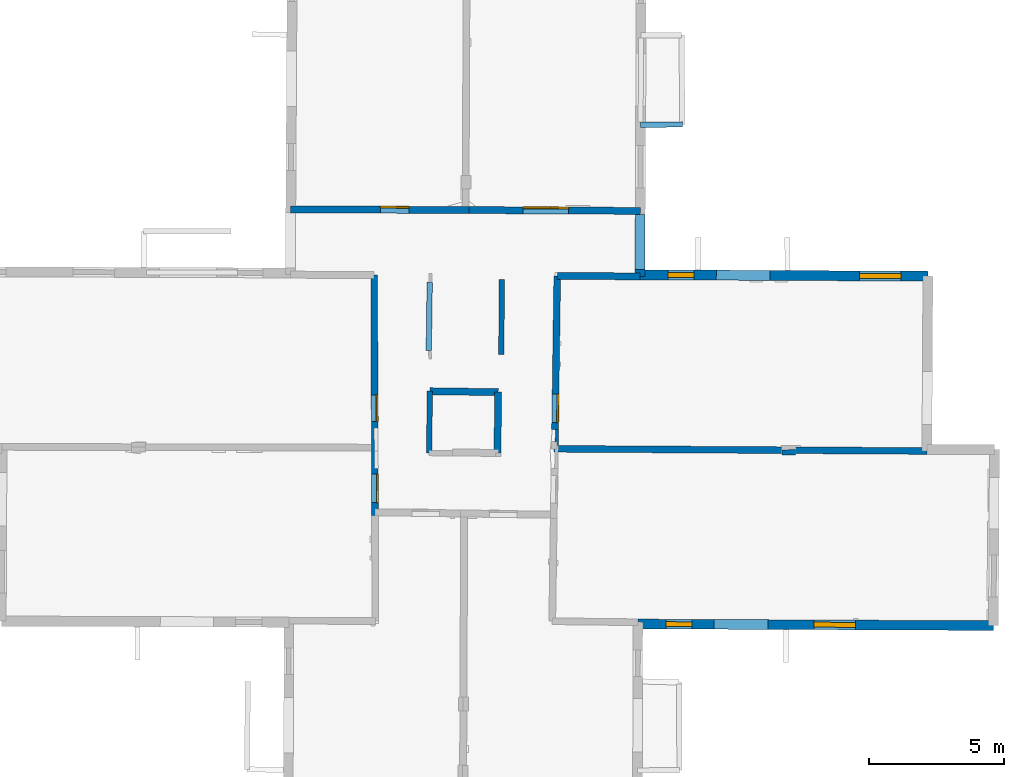
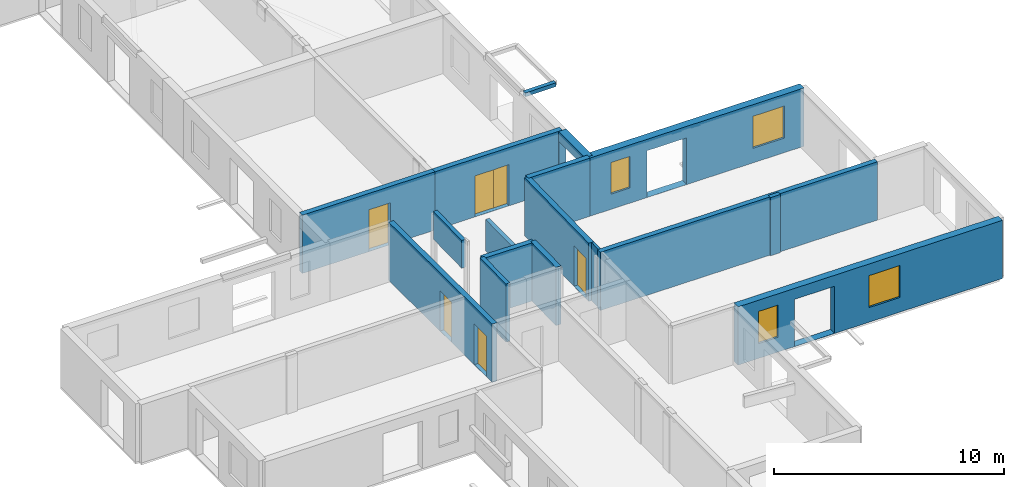
# One storey, part 5 of 15: 17 walls, 6 doors, 4 windows, 13 openings.
"""IFC2X3 building model written with IfcOpenShell, lengths in metres."""

from ifc_helpers import new_model, entity, si_unit, converted_unit, derived_unit, direction, frame, frame_2d, origin, origin_2d_with_axis, place, context, subcontext, project, spatial, polyline, rectangle, outline, extrude, source, transform, mapped, material, layer, layer_set, layer_usage, type_object, type_shapes, element, fill, save


model = new_model("IFC2X3")

# Units and contexts
model_context = context("Model", 3, precision=1e-05, world=origin(), true_north=direction((0.0, 1.0)))
body_context = subcontext(model_context, "Body", "Model", "MODEL_VIEW")
ifc_project = project(units=[si_unit("LENGTHUNIT", "METRE"), si_unit("AREAUNIT", "SQUARE_METRE"), si_unit("VOLUMEUNIT", "CUBIC_METRE"), converted_unit("PLANEANGLEUNIT", "DEGREE", entity("IfcRatioMeasure", 0.0174532925199433), si_unit("PLANEANGLEUNIT", "RADIAN"), dimensions=[0, 0, 0, 0, 0, 0, 0]), si_unit("MASSUNIT", "GRAM", prefix="KILO"), derived_unit("MASSDENSITYUNIT", [(si_unit("MASSUNIT", "GRAM", prefix="KILO"), 1), (si_unit("LENGTHUNIT", "METRE"), -3)]), derived_unit("MOMENTOFINERTIAUNIT", [(si_unit("LENGTHUNIT", "METRE"), 4)]), si_unit("TIMEUNIT", "SECOND"), si_unit("FREQUENCYUNIT", "HERTZ"), si_unit("THERMODYNAMICTEMPERATUREUNIT", "DEGREE_CELSIUS"), derived_unit("THERMALTRANSMITTANCEUNIT", [(si_unit("MASSUNIT", "GRAM", prefix="KILO"), 1), (si_unit("THERMODYNAMICTEMPERATUREUNIT", "KELVIN"), -1), (si_unit("TIMEUNIT", "SECOND"), -3)]), derived_unit("VOLUMETRICFLOWRATEUNIT", [(si_unit("LENGTHUNIT", "METRE"), 3), (si_unit("TIMEUNIT", "SECOND"), -1)]), si_unit("ELECTRICCURRENTUNIT", "AMPERE"), si_unit("ELECTRICVOLTAGEUNIT", "VOLT"), si_unit("POWERUNIT", "WATT"), si_unit("FORCEUNIT", "NEWTON", prefix="KILO"), si_unit("ILLUMINANCEUNIT", "LUX"), si_unit("LUMINOUSFLUXUNIT", "LUMEN"), si_unit("LUMINOUSINTENSITYUNIT", "CANDELA"), derived_unit("USERDEFINED", [(si_unit("MASSUNIT", "GRAM", prefix="KILO"), -1), (si_unit("LENGTHUNIT", "METRE"), -2), (si_unit("TIMEUNIT", "SECOND"), 3), (si_unit("LUMINOUSFLUXUNIT", "LUMEN"), 1)]), derived_unit("LINEARVELOCITYUNIT", [(si_unit("LENGTHUNIT", "METRE"), 1), (si_unit("TIMEUNIT", "SECOND"), -1)]), si_unit("PRESSUREUNIT", "PASCAL"), derived_unit("USERDEFINED", [(si_unit("LENGTHUNIT", "METRE"), -2), (si_unit("MASSUNIT", "GRAM", prefix="KILO"), 1), (si_unit("TIMEUNIT", "SECOND"), -2)]), derived_unit("LINEARFORCEUNIT", [(si_unit("MASSUNIT", "GRAM", prefix="KILO"), 1), (si_unit("LENGTHUNIT", "METRE"), 1), (si_unit("TIMEUNIT", "SECOND"), -2), (si_unit("LENGTHUNIT", "METRE"), -1)]), derived_unit("PLANARFORCEUNIT", [(si_unit("MASSUNIT", "GRAM", prefix="KILO"), 1), (si_unit("LENGTHUNIT", "METRE"), 1), (si_unit("TIMEUNIT", "SECOND"), -2), (si_unit("LENGTHUNIT", "METRE"), -2)])], contexts=[model_context])

# Site, building, storey
placement_1 = place(None, origin())
site = spatial("IfcSite", under=ifc_project, at=placement_1, CompositionType="ELEMENT")
building = spatial("IfcBuilding", under=site, at=placement_1, CompositionType="ELEMENT")
storey_placement = place(placement_1, frame((0.0, 0.0, 2.3807327747345)))
storey = spatial("IfcBuildingStorey", under=building, at=storey_placement, Name="Level 2", CompositionType="ELEMENT", Elevation=2.3807327747345)

# Wall
ifc_material_1 = material(Name="Default wall")
ifc_layer_1 = layer(ifc_material_1, 0.25)
ifc_layer_set_1 = layer_set([ifc_layer_1], Name="wall_thickness_0.2500")
ifc_layer_usage_1 = layer_usage(ifc_layer_set_1, "AXIS2", "POSITIVE", -0.125)
wall_type_1 = type_object("IfcWallType", Name="wall_thickness_0.2500", PredefinedType="STANDARD", material=ifc_layer_set_1)
wall_1_placement = place(storey_placement, frame((9.52517846311906, 19.4277841959483, 0.0), z_axis=(0.0, 0.0, 1.0), x_axis=(0.99998290217259, -0.00584768009418763, 0.0)))
element("IfcWallStandardCase", 1, at=wall_1_placement, inside=storey, type_object=wall_type_1, material=ifc_layer_usage_1, Name="Wall:724", ObjectType="Wall", context=body_context, shape_type="SweptSolid", body=[
    extrude(outline(polyline([(13.8512137696322, -0.125), (13.8512137696322, 0.125), (0.0, 0.125), (0.0, -0.125), (13.8512137696322, -0.125)])), origin(), (0.0, 0.0, 1.0), 3.08589615821838),
])

# Wall, opening, door
wall_2_placement = place(storey_placement, frame((9.63678529989591, 25.850561855109, 0.0), z_axis=(0.0, 0.0, 1.0), x_axis=(-0.0145015561496306, -0.999894846906033, 0.0)))
wall_2 = element("IfcWallStandardCase", 2, at=wall_2_placement, inside=storey, type_object=wall_type_1, material=ifc_layer_usage_1, Name="Wall:739", ObjectType="Wall", context=body_context, shape_type="SweptSolid", body=[
    extrude(outline(polyline([(5.69907225176459, -0.125), (5.69907225176459, 0.125), (0.0, 0.125), (0.0, -0.125), (5.69907225176459, -0.125)])), origin(), (0.0, 0.0, 1.0), 3.08589615821838),
])
opening_1_placement = place(wall_2_placement, frame((4.38407267580055, -0.125, 0.00526785850524902)))
opening_1 = element("IfcOpeningElement", 3, at=opening_1_placement, cuts=wall_2, Name="Opening : 1065 x 2145 : 474", ObjectType="Opening", context=body_context, shape_type="SweptSolid", body=[
    extrude(rectangle(XDim=1.065, YDim=2.145, at=frame_2d((1.0725, 0.5325), x_axis=(0.0, 1.0))), frame((0.0, 0.0, 0.0), z_axis=(0.0, 1.0, 0.0), x_axis=(0.0, 0.0, 1.0)), (0.0, 0.0, 1.0), 0.25),
])
ifc_material_2 = material(Name="Door Panel")
door_style_1 = type_object("IfcDoorStyle", Name="Door : 1065 x 2145mm", ConstructionType="NOTDEFINED", OperationType="SINGLE_SWING_RIGHT", ParameterTakesPrecedence=False, Sizeable=False, material=ifc_material_2)
shared_shape_1 = source(origin(), body_context, "Body", "SweptSolid", [
    extrude(rectangle(XDim=0.0625, YDim=1.065, at=origin_2d_with_axis()), frame((0.5325, 0.21875, 0.0), z_axis=(0.0, 0.0, 1.0), x_axis=(0.0, 1.0, 0.0)), (0.0, 0.0, 1.0), 2.145),
])
type_shapes(door_style_1, [shared_shape_1])
door_1_placement = place(opening_1_placement, origin())
door_1 = element("IfcDoor", 4, at=door_1_placement, inside=storey, type_object=door_style_1, Name="Door : 1065 x 2145mm : 90", ObjectType="Door : 1065 x 2145mm", OverallHeight=2.145, OverallWidth=1.065, context=body_context, shape_type="MappedRepresentation", body=[
    mapped(shared_shape_1, transform((0.0, 0.0, 0.0), scale=1.0)),
])
fill(opening_1, door_1)

# Wall, openings, doors
wall_3_placement = place(storey_placement, frame((2.8325803450543, 25.8867340874099, 0.0), z_axis=(0.0, 0.0, 1.0), x_axis=(0.00334229316421513, -0.999994414522604, 0.0)))
wall_3 = element("IfcWallStandardCase", 5, at=wall_3_placement, inside=storey, type_object=wall_type_1, material=ifc_layer_usage_1, Name="Wall:750", ObjectType="Wall", context=body_context, shape_type="SweptSolid", body=[
    extrude(outline(polyline([(8.94604720610364, -0.125), (8.94604720610364, 0.125), (0.0, 0.125), (0.0, -0.125), (8.94604720610364, -0.125)])), origin(), (0.0, 0.0, 1.0), 3.08589615821838),
])
opening_2_placement = place(wall_3_placement, frame((4.45362671444788, -0.125, 0.00526785850524902)))
opening_2 = element("IfcOpeningElement", 6, at=opening_2_placement, cuts=wall_3, Name="Opening : 985 x 2130 : 481", ObjectType="Opening", context=body_context, shape_type="SweptSolid", body=[
    extrude(rectangle(XDim=0.985, YDim=2.13, at=frame_2d((1.065, 0.4925), x_axis=(0.0, 1.0))), frame((0.0, 0.0, 0.0), z_axis=(0.0, 1.0, 0.0), x_axis=(0.0, 0.0, 1.0)), (0.0, 0.0, 1.0), 0.25),
])
opening_3_placement = place(wall_3_placement, frame((7.39870770809691, -0.125, 0.00526785850524902)))
opening_3 = element("IfcOpeningElement", 7, at=opening_3_placement, cuts=wall_3, Name="Opening : 1060 x 2155 : 482", ObjectType="Opening", context=body_context, shape_type="SweptSolid", body=[
    extrude(rectangle(XDim=1.06, YDim=2.155, at=frame_2d((1.0775, 0.53), x_axis=(0.0, 1.0))), frame((0.0, 0.0, 0.0), z_axis=(0.0, 1.0, 0.0), x_axis=(0.0, 0.0, 1.0)), (0.0, 0.0, 1.0), 0.25),
])
door_style_2 = type_object("IfcDoorStyle", Name="Door : 985 x 2130mm", ConstructionType="NOTDEFINED", OperationType="SINGLE_SWING_RIGHT", ParameterTakesPrecedence=False, Sizeable=False, material=ifc_material_2)
shared_shape_2 = source(origin(), body_context, "Body", "SweptSolid", [
    extrude(rectangle(XDim=0.0625, YDim=0.985, at=origin_2d_with_axis()), frame((0.4925, 0.21875, 0.0), z_axis=(0.0, 0.0, 1.0), x_axis=(0.0, 1.0, 0.0)), (0.0, 0.0, 1.0), 2.13),
])
type_shapes(door_style_2, [shared_shape_2])
door_2_placement = place(opening_2_placement, origin())
door_2 = element("IfcDoor", 8, at=door_2_placement, inside=storey, type_object=door_style_2, Name="Door : 985 x 2130mm : 92", ObjectType="Door : 985 x 2130mm", OverallHeight=2.13, OverallWidth=0.985, context=body_context, shape_type="MappedRepresentation", body=[
    mapped(shared_shape_2, transform((0.0, 0.0, 0.0), scale=1.0)),
])
fill(opening_2, door_2)
door_style_3 = type_object("IfcDoorStyle", Name="Door : 1060 x 2155mm", ConstructionType="NOTDEFINED", OperationType="SINGLE_SWING_RIGHT", ParameterTakesPrecedence=False, Sizeable=False, material=ifc_material_2)
shared_shape_3 = source(origin(), body_context, "Body", "SweptSolid", [
    extrude(rectangle(XDim=0.0625, YDim=1.06, at=origin_2d_with_axis()), frame((0.53, 0.21875, 0.0), z_axis=(0.0, 0.0, 1.0), x_axis=(0.0, 1.0, 0.0)), (0.0, 0.0, 1.0), 2.155),
])
type_shapes(door_style_3, [shared_shape_3])
door_3_placement = place(opening_3_placement, origin())
door_3 = element("IfcDoor", 9, at=door_3_placement, inside=storey, type_object=door_style_3, Name="Door : 1060 x 2155mm : 93", ObjectType="Door : 1060 x 2155mm", OverallHeight=2.155, OverallWidth=1.06, context=body_context, shape_type="MappedRepresentation", body=[
    mapped(shared_shape_3, transform((0.0, 0.0, 0.0), scale=1.0)),
])
fill(opening_3, door_3)

# Walls
ifc_layer_2 = layer(ifc_material_1, 0.2)
ifc_layer_set_2 = layer_set([ifc_layer_2], Name="wall_thickness_0.2000")
ifc_layer_usage_2 = layer_usage(ifc_layer_set_2, "AXIS2", "POSITIVE", -0.1)
wall_type_2 = type_object("IfcWallType", Name="wall_thickness_0.2000", PredefinedType="STANDARD", material=ifc_layer_set_2)
placement_2 = place(placement_1, frame((0.0, 0.0, 3.99499988555908)))
wall_4_placement = place(placement_2, frame((4.86172145837155, 23.0868806920624, 0.0), z_axis=(0.0, 0.0, 1.0), x_axis=(0.0138378963437509, 0.999904251728524, 0.0)))
element("IfcWallStandardCase", 10, at=wall_4_placement, inside=storey, type_object=wall_type_2, material=ifc_layer_usage_2, Name="Wall:716", ObjectType="Wall", context=body_context, shape_type="SweptSolid", body=[
    extrude(outline(polyline([(2.52999878903139, -0.1), (2.52999878903139, 0.1), (0.0, 0.1), (0.0, -0.1), (2.52999878903139, -0.1)])), origin(), (0.0, 0.0, 1.0), 1.4716290473938),
])
wall_5_placement = place(storey_placement, frame((7.57779153173863, 25.7257712059022, 0.0), z_axis=(0.0, 0.0, 1.0), x_axis=(-0.00726444214638793, -0.99997361359203, 0.0)))
element("IfcWallStandardCase", 11, at=wall_5_placement, inside=storey, type_object=wall_type_2, material=ifc_layer_usage_2, Name="Wall:773", ObjectType="Wall", context=body_context, shape_type="SweptSolid", body=[
    extrude(outline(polyline([(2.8000006397717, -0.1), (2.8000006397717, 0.1), (0.0, 0.1), (0.0, -0.1), (2.8000006397717, -0.1)])), origin(), (0.0, 0.0, 1.0), 1.65126729011536),
])
wall_6_placement = place(storey_placement, frame((17.9921527331697, 19.2920920371607, 0.0), z_axis=(0.0, 0.0, 1.0), x_axis=(0.999991416526295, 0.00414329261992554, 0.0)))
element("IfcWallStandardCase", 12, at=wall_6_placement, inside=storey, type_object=wall_type_2, material=ifc_layer_usage_2, Name="Wall:807", ObjectType="Wall", context=body_context, shape_type="SweptSolid", body=[
    extrude(outline(polyline([(0.504999680720817, -0.1), (0.504999680720817, 0.1), (0.0, 0.1), (0.0, -0.1), (0.504999680720817, -0.1)])), origin(), (0.0, 0.0, 1.0), 3.08589615821838),
])
placement_3 = place(placement_1, frame((0.0, 0.0, 5.26399993896484)))
wall_7_placement = place(placement_3, frame((12.7357337186194, 31.4702623237995, 0.0), z_axis=(0.0, 0.0, 1.0), x_axis=(0.999967695594601, 0.00803789569625922, 0.0)))
element("IfcWallStandardCase", 13, at=wall_7_placement, inside=storey, type_object=wall_type_2, material=ifc_layer_usage_2, Name="Wall:811", ObjectType="Wall", context=body_context, shape_type="SweptSolid", body=[
    extrude(outline(polyline([(1.54810947425704, -0.1), (1.54810947425704, 0.1), (0.0, 0.1), (0.0, -0.1), (1.54810947425704, -0.1)])), origin(), (0.0, 0.0, 1.0), 0.202628993988037),
])
wall_8_placement = place(storey_placement, frame((4.90475104188143, 21.5686303125142, 0.0), z_axis=(0.0, 0.0, 1.0), x_axis=(-0.0143994759418368, -0.999896322171754, 0.0)))
element("IfcWallStandardCase", 14, at=wall_8_placement, inside=storey, type_object=wall_type_2, material=ifc_layer_usage_2, Name="Wall:834", ObjectType="Wall", context=body_context, shape_type="SweptSolid", body=[
    extrude(outline(polyline([(2.2977102217278, -0.1), (2.2977102217278, 0.1), (0.0, 0.1), (0.0, -0.1), (2.2977102217278, -0.1)])), origin(), (0.0, 0.0, 1.0), 3.08589615821838),
])
ifc_layer_3 = layer(ifc_material_1, 0.259999990463257)
ifc_layer_set_3 = layer_set([ifc_layer_3], Name="wall_thickness_0.2600")
ifc_layer_usage_3 = layer_usage(ifc_layer_set_3, "AXIS2", "POSITIVE", -0.129999995231628)
wall_type_3 = type_object("IfcWallType", Name="wall_thickness_0.2600", PredefinedType="STANDARD", material=ifc_layer_set_3)
wall_9_placement = place(storey_placement, frame((9.6367857093137, 25.8505635935053, 0.0), z_axis=(0.0, 0.0, 1.0), x_axis=(0.999989396078705, -0.00460518513710446, 0.0)))
element("IfcWallStandardCase", 15, at=wall_9_placement, inside=storey, type_object=wall_type_3, material=ifc_layer_usage_3, Name="Wall:694", ObjectType="Wall", context=body_context, shape_type="SweptSolid", body=[
    extrude(outline(polyline([(3.07400053011447, -0.129999995231628), (3.07400053011447, 0.129999995231628), (0.0, 0.129999995231628), (0.0, -0.129999995231628), (3.07400053011447, -0.129999995231628)])), origin(), (0.0, 0.0, 1.0), 3.08589615821838),
])
wall_10_placement = place(storey_placement, frame((4.90475087953654, 21.5686325150331, 0.0), z_axis=(0.0, 0.0, 1.0), x_axis=(0.999902557254078, -0.0139597993092914, 0.0)))
element("IfcWallStandardCase", 16, at=wall_10_placement, inside=storey, type_object=wall_type_3, material=ifc_layer_usage_3, Name="Wall:761", ObjectType="Wall", context=body_context, shape_type="SweptSolid", body=[
    extrude(outline(polyline([(2.53861368723754, -0.129999995231628), (2.53861368723754, 0.129999995231628), (0.0, 0.129999995231628), (0.0, -0.129999995231628), (2.53861368723754, -0.129999995231628)])), origin(), (0.0, 0.0, 1.0), 3.08589615821838),
])
wall_11_placement = place(storey_placement, frame((7.44311694937993, 21.5331939186605, 0.0), z_axis=(0.0, 0.0, 1.0), x_axis=(-0.0135836358845427, -0.999907738161955, 0.0)))
element("IfcWallStandardCase", 17, at=wall_11_placement, inside=storey, type_object=wall_type_3, material=ifc_layer_usage_3, Name="Wall:803", ObjectType="Wall", context=body_context, shape_type="SweptSolid", body=[
    extrude(outline(polyline([(2.25917488154989, -0.129999995231628), (2.25917488154989, 0.129999995231628), (0.0, 0.129999995231628), (0.0, -0.129999995231628), (2.25917488154989, -0.129999995231628)])), origin(), (0.0, 0.0, 1.0), 3.08589615821838),
])

# Wall, opening, door
wall_12_placement = place(storey_placement, frame((-0.268446166738548, 28.3301176416943, 0.0), z_axis=(0.0, 0.0, 1.0), x_axis=(0.999989445243361, -0.00459449691206746, 0.0)))
wall_12 = element("IfcWallStandardCase", 18, at=wall_12_placement, inside=storey, type_object=wall_type_3, material=ifc_layer_usage_3, Name="Wall:815", ObjectType="Wall", context=body_context, shape_type="SweptSolid", body=[
    extrude(outline(polyline([(6.62352114256391, -0.129999995231628), (6.62352114256391, 0.129999995231628), (0.0, 0.129999995231628), (0.0, -0.129999995231628), (6.62352114256391, -0.129999995231628)])), origin(), (0.0, 0.0, 1.0), 3.08589615821838),
])
opening_4_placement = place(wall_12_placement, frame((3.33346524334718, -0.129999995231628, 0.00526785850524902)))
opening_4 = element("IfcOpeningElement", 19, at=opening_4_placement, cuts=wall_12, Name="Opening : 1055 x 2215 : 518", ObjectType="Opening", context=body_context, shape_type="SweptSolid", body=[
    extrude(rectangle(XDim=1.055, YDim=2.215, at=frame_2d((1.1075, 0.5275), x_axis=(0.0, 1.0))), frame((0.0, 0.0, 0.0), z_axis=(0.0, 1.0, 0.0), x_axis=(0.0, 0.0, 1.0)), (0.0, 0.0, 1.0), 0.259999990463257),
])
door_style_4 = type_object("IfcDoorStyle", Name="Door : 1055 x 2215mm", ConstructionType="NOTDEFINED", OperationType="SINGLE_SWING_RIGHT", ParameterTakesPrecedence=False, Sizeable=False, material=ifc_material_2)
shared_shape_4 = source(origin(), body_context, "Body", "SweptSolid", [
    extrude(rectangle(XDim=0.0649999976158142, YDim=1.055, at=origin_2d_with_axis()), frame((0.5275, 0.22749999165535, 0.0), z_axis=(0.0, 0.0, 1.0), x_axis=(0.0, 1.0, 0.0)), (0.0, 0.0, 1.0), 2.215),
])
type_shapes(door_style_4, [shared_shape_4])
door_4_placement = place(opening_4_placement, origin())
door_4 = element("IfcDoor", 20, at=door_4_placement, inside=storey, type_object=door_style_4, Name="Door : 1055 x 2215mm : 96", ObjectType="Door : 1055 x 2215mm", OverallHeight=2.215, OverallWidth=1.055, context=body_context, shape_type="MappedRepresentation", body=[
    mapped(shared_shape_4, transform((0.0, 0.0, 0.0), scale=1.0)),
])
fill(opening_4, door_4)

# Wall, openings, doors
wall_13_placement = place(storey_placement, frame((6.35500506617161, 28.2996858942578, 0.0), z_axis=(0.0, 0.0, 1.0), x_axis=(0.999989444061181, -0.00459475420556232, 0.0)))
wall_13 = element("IfcWallStandardCase", 21, at=wall_13_placement, inside=storey, type_object=wall_type_3, material=ifc_layer_usage_3, Name="Wall:816", ObjectType="Wall", context=body_context, shape_type="SweptSolid", body=[
    extrude(outline(polyline([(6.36660954486579, -0.129999995231628), (6.36660954486579, 0.129999995231628), (0.0, 0.129999995231628), (0.0, -0.129999995231628), (6.36660954486579, -0.129999995231628)])), origin(), (0.0, 0.0, 1.0), 3.08589615821838),
])
opening_5_placement = place(wall_13_placement, frame((3.03494465240169, -0.129999995231628, 0.00526785850524902)))
opening_5 = element("IfcOpeningElement", 22, at=opening_5_placement, cuts=wall_13, Name="Opening : 670 x 2180 : 519", ObjectType="Opening", context=body_context, shape_type="SweptSolid", body=[
    extrude(rectangle(XDim=0.67, YDim=2.18, at=frame_2d((1.09, 0.335), x_axis=(0.0, 1.0))), frame((0.0, 0.0, 0.0), z_axis=(0.0, 1.0, 0.0), x_axis=(0.0, 0.0, 1.0)), (0.0, 0.0, 1.0), 0.259999990463257),
])
opening_6_placement = place(wall_13_placement, frame((2.00994565985803, -0.129999995231628, 0.00526785850524902)))
opening_6 = element("IfcOpeningElement", 23, at=opening_6_placement, cuts=wall_13, Name="Opening : 1040 x 2170 : 520", ObjectType="Opening", context=body_context, shape_type="SweptSolid", body=[
    extrude(rectangle(XDim=1.04, YDim=2.17, at=frame_2d((1.085, 0.52), x_axis=(0.0, 1.0))), frame((0.0, 0.0, 0.0), z_axis=(0.0, 1.0, 0.0), x_axis=(0.0, 0.0, 1.0)), (0.0, 0.0, 1.0), 0.259999990463257),
])
door_style_5 = type_object("IfcDoorStyle", Name="Door : 670 x 2180mm", ConstructionType="NOTDEFINED", OperationType="SINGLE_SWING_RIGHT", ParameterTakesPrecedence=False, Sizeable=False, material=ifc_material_2)
shared_shape_5 = source(origin(), body_context, "Body", "SweptSolid", [
    extrude(rectangle(XDim=0.0649999976158142, YDim=0.67, at=origin_2d_with_axis()), frame((0.335, 0.22749999165535, 0.0), z_axis=(0.0, 0.0, 1.0), x_axis=(0.0, 1.0, 0.0)), (0.0, 0.0, 1.0), 2.18),
])
type_shapes(door_style_5, [shared_shape_5])
door_5_placement = place(opening_5_placement, origin())
door_5 = element("IfcDoor", 24, at=door_5_placement, inside=storey, type_object=door_style_5, Name="Door : 670 x 2180mm : 97", ObjectType="Door : 670 x 2180mm", OverallHeight=2.18, OverallWidth=0.67, context=body_context, shape_type="MappedRepresentation", body=[
    mapped(shared_shape_5, transform((0.0, 0.0, 0.0), scale=1.0)),
])
fill(opening_5, door_5)
door_style_6 = type_object("IfcDoorStyle", Name="Door : 1040 x 2170mm", ConstructionType="NOTDEFINED", OperationType="SINGLE_SWING_RIGHT", ParameterTakesPrecedence=False, Sizeable=False, material=ifc_material_2)
shared_shape_6 = source(origin(), body_context, "Body", "SweptSolid", [
    extrude(rectangle(XDim=0.0649999976158142, YDim=1.04, at=origin_2d_with_axis()), frame((0.52, 0.22749999165535, 0.0), z_axis=(0.0, 0.0, 1.0), x_axis=(0.0, 1.0, 0.0)), (0.0, 0.0, 1.0), 2.17),
])
type_shapes(door_style_6, [shared_shape_6])
door_6_placement = place(opening_6_placement, origin())
door_6 = element("IfcDoor", 25, at=door_6_placement, inside=storey, type_object=door_style_6, Name="Door : 1040 x 2170mm : 98", ObjectType="Door : 1040 x 2170mm", OverallHeight=2.17, OverallWidth=1.04, context=body_context, shape_type="MappedRepresentation", body=[
    mapped(shared_shape_6, transform((0.0, 0.0, 0.0), scale=1.0)),
])
fill(opening_6, door_6)

# Wall
ifc_layer_4 = layer(ifc_material_1, 0.119999997317791)
ifc_layer_set_4 = layer_set([ifc_layer_4], Name="wall_thickness_0.1200")
ifc_layer_usage_4 = layer_usage(ifc_layer_set_4, "AXIS2", "POSITIVE", -0.0599999986588955)
wall_type_4 = type_object("IfcWallType", Name="wall_thickness_0.1200", PredefinedType="STANDARD", material=ifc_layer_set_4)
wall_14_placement = place(storey_placement, frame((9.62849399635562, 20.1512580744275, 0.0), z_axis=(0.0, 0.0, 1.0), x_axis=(-0.0193982806967049, -0.999811835650095, 0.0)))
element("IfcWallStandardCase", 26, at=wall_14_placement, inside=storey, type_object=wall_type_4, material=ifc_layer_usage_4, Name="Wall:771", ObjectType="Wall", context=body_context, shape_type="SweptSolid", body=[
    extrude(outline(polyline([(0.599933976884989, -0.0599999986588955), (0.599933976884989, 0.0599999986588955), (0.0, 0.0599999986588955), (0.0, -0.0599999986588955), (0.599933976884989, -0.0599999986588955)])), origin(), (0.0, 0.0, 1.0), 3.08589615821838),
])

# Wall, openings, windows
ifc_layer_5 = layer(ifc_material_1, 0.370000004768372)
ifc_layer_set_5 = layer_set([ifc_layer_5], Name="wall_thickness_0.3700")
ifc_layer_usage_5 = layer_usage(ifc_layer_set_5, "AXIS2", "POSITIVE", -0.185000002384186)
wall_type_5 = type_object("IfcWallType", Name="wall_thickness_0.3700", PredefinedType="STANDARD", material=ifc_layer_set_5)
wall_15_placement = place(storey_placement, frame((12.7110165506372, 25.8957175480013, 0.0), z_axis=(0.0, 0.0, 1.0), x_axis=(0.999987183389355, -0.00506290993637916, 0.0)))
wall_15 = element("IfcWallStandardCase", 27, at=wall_15_placement, inside=storey, type_object=wall_type_5, material=ifc_layer_usage_5, Name="Wall:717", ObjectType="Wall", context=body_context, shape_type="SweptSolid", body=[
    extrude(outline(polyline([(10.7013843707478, -0.185000002384186), (10.7013843707478, 0.185000002384186), (0.0, 0.185000002384186), (0.0, -0.185000002384186), (10.7013843707478, -0.185000002384186)])), origin(), (0.0, 0.0, 1.0), 3.08589615821838),
])
opening_7_placement = place(wall_15_placement, frame((2.83458048400293, -0.185000002384186, 0.00526785850524902)))
element("IfcOpeningElement", 28, at=opening_7_placement, cuts=wall_15, Name="Opening : 1990 x 2475 : 455", ObjectType="Opening", context=body_context, shape_type="SweptSolid", body=[
    extrude(rectangle(XDim=1.99, YDim=2.475, at=frame_2d((1.2375, 0.995), x_axis=(0.0, 1.0))), frame((0.0, 0.0, 0.0), z_axis=(0.0, 1.0, 0.0), x_axis=(0.0, 0.0, 1.0)), (0.0, 0.0, 1.0), 0.370000004768372),
])
opening_8_placement = place(wall_15_placement, frame((8.14958048096227, -0.185000002384186, 0.770267724990845)))
opening_8 = element("IfcOpeningElement", 29, at=opening_8_placement, cuts=wall_15, Name="Opening : 1555 x 1700 : 456", ObjectType="Opening", context=body_context, shape_type="SweptSolid", body=[
    extrude(rectangle(XDim=1.555, YDim=1.7, at=frame_2d((0.85, 0.7775), x_axis=(0.0, 1.0))), frame((0.0, 0.0, 0.0), z_axis=(0.0, 1.0, 0.0), x_axis=(0.0, 0.0, 1.0)), (0.0, 0.0, 1.0), 0.370000004768372),
])
opening_9_placement = place(wall_15_placement, frame((1.03457820385903, -0.185000002384186, 0.805267810821533)))
opening_9 = element("IfcOpeningElement", 30, at=opening_9_placement, cuts=wall_15, Name="Opening : 970 x 1675 : 457", ObjectType="Opening", context=body_context, shape_type="SweptSolid", body=[
    extrude(rectangle(XDim=0.97, YDim=1.675, at=frame_2d((0.8375, 0.485), x_axis=(0.0, 1.0))), frame((0.0, 0.0, 0.0), z_axis=(0.0, 1.0, 0.0), x_axis=(0.0, 0.0, 1.0)), (0.0, 0.0, 1.0), 0.370000004768372),
])
ifc_material_3 = material(Name="Window Default")
window_style_1 = type_object("IfcWindowStyle", Name="Window : 1555 x 1700mm", ConstructionType="NOTDEFINED", OperationType="NOTDEFINED", ParameterTakesPrecedence=False, Sizeable=False, material=ifc_material_3)
shared_shape_7 = source(origin(), body_context, "Body", "SweptSolid", [
    extrude(rectangle(XDim=0.185000002384186, YDim=1.555, at=origin_2d_with_axis()), frame((0.7775, 0.185000002384186, 0.0), z_axis=(0.0, 0.0, 1.0), x_axis=(0.0, 1.0, 0.0)), (0.0, 0.0, 1.0), 1.7),
])
type_shapes(window_style_1, [shared_shape_7])
window_1_placement = place(opening_8_placement, origin())
window_1 = element("IfcWindow", 31, at=window_1_placement, inside=storey, type_object=window_style_1, Name="Window : 1555 x 1700mm : 248", ObjectType="Window : 1555 x 1700mm", OverallHeight=1.7, OverallWidth=1.555, context=body_context, shape_type="MappedRepresentation", body=[
    mapped(shared_shape_7, transform((0.0, 0.0, 0.0), scale=1.0)),
])
fill(opening_8, window_1)
window_style_2 = type_object("IfcWindowStyle", Name="Window : 970 x 1675mm", ConstructionType="NOTDEFINED", OperationType="NOTDEFINED", ParameterTakesPrecedence=False, Sizeable=False, material=ifc_material_3)
shared_shape_8 = source(origin(), body_context, "Body", "SweptSolid", [
    extrude(rectangle(XDim=0.185000002384186, YDim=0.97, at=origin_2d_with_axis()), frame((0.485, 0.185000002384186, 0.0), z_axis=(0.0, 0.0, 1.0), x_axis=(0.0, 1.0, 0.0)), (0.0, 0.0, 1.0), 1.675),
])
type_shapes(window_style_2, [shared_shape_8])
window_2_placement = place(opening_9_placement, origin())
window_2 = element("IfcWindow", 32, at=window_2_placement, inside=storey, type_object=window_style_2, Name="Window : 970 x 1675mm : 249", ObjectType="Window : 970 x 1675mm", OverallHeight=1.675, OverallWidth=0.97, context=body_context, shape_type="MappedRepresentation", body=[
    mapped(shared_shape_8, transform((0.0, 0.0, 0.0), scale=1.0)),
])
fill(opening_9, window_2)

# Wall, opening
wall_16_placement = place(storey_placement, frame((12.7209695285883, 28.1404362976718, 0.0), z_axis=(0.0, 0.0, 1.0), x_axis=(-0.00443382301248866, -0.999990170558438, 0.0)))
wall_16 = element("IfcWallStandardCase", 33, at=wall_16_placement, inside=storey, type_object=wall_type_5, material=ifc_layer_usage_5, Name="Wall:800", ObjectType="Wall", context=body_context, shape_type="SweptSolid", body=[
    extrude(outline(polyline([(2.30405211226727, -0.185000002384186), (2.30405211226727, 0.185000002384186), (0.0, 0.185000002384186), (0.0, -0.185000002384186), (2.30405211226727, -0.185000002384186)])), origin(), (0.0, 0.0, 1.0), 3.08589615821838),
])
opening_10_placement = place(wall_16_placement, frame((0.011835242328443, -0.185000002384186, 0.00526785850524902)))
element("IfcOpeningElement", 34, at=opening_10_placement, cuts=wall_16, Name="Opening : 2035 x 2555 : 511", ObjectType="Opening", context=body_context, shape_type="SweptSolid", body=[
    extrude(rectangle(XDim=2.035, YDim=2.555, at=frame_2d((1.2775, 1.0175), x_axis=(0.0, 1.0))), frame((0.0, 0.0, 0.0), z_axis=(0.0, 1.0, 0.0), x_axis=(0.0, 0.0, 1.0)), (0.0, 0.0, 1.0), 0.370000004768372),
])

# Wall, openings, windows
ifc_layer_6 = layer(ifc_material_1, 0.360000014305115)
ifc_layer_set_6 = layer_set([ifc_layer_6], Name="wall_thickness_0.3600")
ifc_layer_usage_6 = layer_usage(ifc_layer_set_6, "AXIS2", "POSITIVE", -0.180000007152557)
wall_type_6 = type_object("IfcWallType", Name="wall_thickness_0.3600", PredefinedType="STANDARD", material=ifc_layer_set_6)
wall_17_placement = place(storey_placement, frame((12.6351613899745, 12.9174973887554, 0.0), z_axis=(0.0, 0.0, 1.0), x_axis=(0.99998969235413, -0.00454039486073161, 0.0)))
wall_17 = element("IfcWallStandardCase", 35, at=wall_17_placement, inside=storey, type_object=wall_type_6, material=ifc_layer_usage_6, Name="Wall:827", ObjectType="Wall", context=body_context, shape_type="SweptSolid", body=[
    extrude(outline(polyline([(13.2152222011069, -0.180000007152557), (13.2152222011069, 0.180000007152557), (0.0, 0.180000007152557), (0.0, -0.180000007152557), (13.2152222011069, -0.180000007152557)])), origin(), (0.0, 0.0, 1.0), 3.08589615821838),
])
opening_11_placement = place(wall_17_placement, frame((2.83116395641377, -0.180000007152557, 0.00526785850524902)))
element("IfcOpeningElement", 36, at=opening_11_placement, cuts=wall_17, Name="Opening : 1995 x 2500 : 526", ObjectType="Opening", context=body_context, shape_type="SweptSolid", body=[
    extrude(rectangle(XDim=1.995, YDim=2.5, at=frame_2d((1.25, 0.9975), x_axis=(0.0, 1.0))), frame((0.0, 0.0, 0.0), z_axis=(0.0, 1.0, 0.0), x_axis=(0.0, 0.0, 1.0)), (0.0, 0.0, 1.0), 0.360000014305115),
])
opening_12_placement = place(wall_17_placement, frame((6.53616392593572, -0.180000007152557, 0.775267839431763)))
opening_12 = element("IfcOpeningElement", 37, at=opening_12_placement, cuts=wall_17, Name="Opening : 1555 x 1695 : 527", ObjectType="Opening", context=body_context, shape_type="SweptSolid", body=[
    extrude(rectangle(XDim=1.555, YDim=1.695, at=frame_2d((0.8475, 0.7775), x_axis=(0.0, 1.0))), frame((0.0, 0.0, 0.0), z_axis=(0.0, 1.0, 0.0), x_axis=(0.0, 0.0, 1.0)), (0.0, 0.0, 1.0), 0.360000014305115),
])
opening_13_placement = place(wall_17_placement, frame((1.03616254363033, -0.180000007152557, 0.78526759147644)))
opening_13 = element("IfcOpeningElement", 38, at=opening_13_placement, cuts=wall_17, Name="Opening : 975 x 1705 : 528", ObjectType="Opening", context=body_context, shape_type="SweptSolid", body=[
    extrude(rectangle(XDim=0.975, YDim=1.705, at=frame_2d((0.8525, 0.4875), x_axis=(0.0, 1.0))), frame((0.0, 0.0, 0.0), z_axis=(0.0, 1.0, 0.0), x_axis=(0.0, 0.0, 1.0)), (0.0, 0.0, 1.0), 0.360000014305115),
])
window_style_3 = type_object("IfcWindowStyle", Name="Window : 1555 x 1695mm", ConstructionType="NOTDEFINED", OperationType="NOTDEFINED", ParameterTakesPrecedence=False, Sizeable=False, material=ifc_material_3)
shared_shape_9 = source(origin(), body_context, "Body", "SweptSolid", [
    extrude(rectangle(XDim=0.185000002384186, YDim=1.555, at=origin_2d_with_axis()), frame((0.7775, 0.185000002384186, 0.0), z_axis=(0.0, 0.0, 1.0), x_axis=(0.0, 1.0, 0.0)), (0.0, 0.0, 1.0), 1.695),
])
type_shapes(window_style_3, [shared_shape_9])
window_3_placement = place(opening_12_placement, origin())
window_3 = element("IfcWindow", 39, at=window_3_placement, inside=storey, type_object=window_style_3, Name="Window : 1555 x 1695mm : 282", ObjectType="Window : 1555 x 1695mm", OverallHeight=1.695, OverallWidth=1.555, context=body_context, shape_type="MappedRepresentation", body=[
    mapped(shared_shape_9, transform((0.0, 0.0, 0.0), scale=1.0)),
])
fill(opening_12, window_3)
window_style_4 = type_object("IfcWindowStyle", Name="Window : 975 x 1705mm", ConstructionType="NOTDEFINED", OperationType="NOTDEFINED", ParameterTakesPrecedence=False, Sizeable=False, material=ifc_material_3)
shared_shape_10 = source(origin(), body_context, "Body", "SweptSolid", [
    extrude(rectangle(XDim=0.180000007152557, YDim=0.975, at=origin_2d_with_axis()), frame((0.4875, 0.180000007152557, 0.0), z_axis=(0.0, 0.0, 1.0), x_axis=(0.0, 1.0, 0.0)), (0.0, 0.0, 1.0), 1.705),
])
type_shapes(window_style_4, [shared_shape_10])
window_4_placement = place(opening_13_placement, origin())
window_4 = element("IfcWindow", 40, at=window_4_placement, inside=storey, type_object=window_style_4, Name="Window : 975 x 1705mm : 283", ObjectType="Window : 975 x 1705mm", OverallHeight=1.705, OverallWidth=0.975, context=body_context, shape_type="MappedRepresentation", body=[
    mapped(shared_shape_10, transform((0.0, 0.0, 0.0), scale=1.0)),
])
fill(opening_13, window_4)

save(model, "model.ifc")
